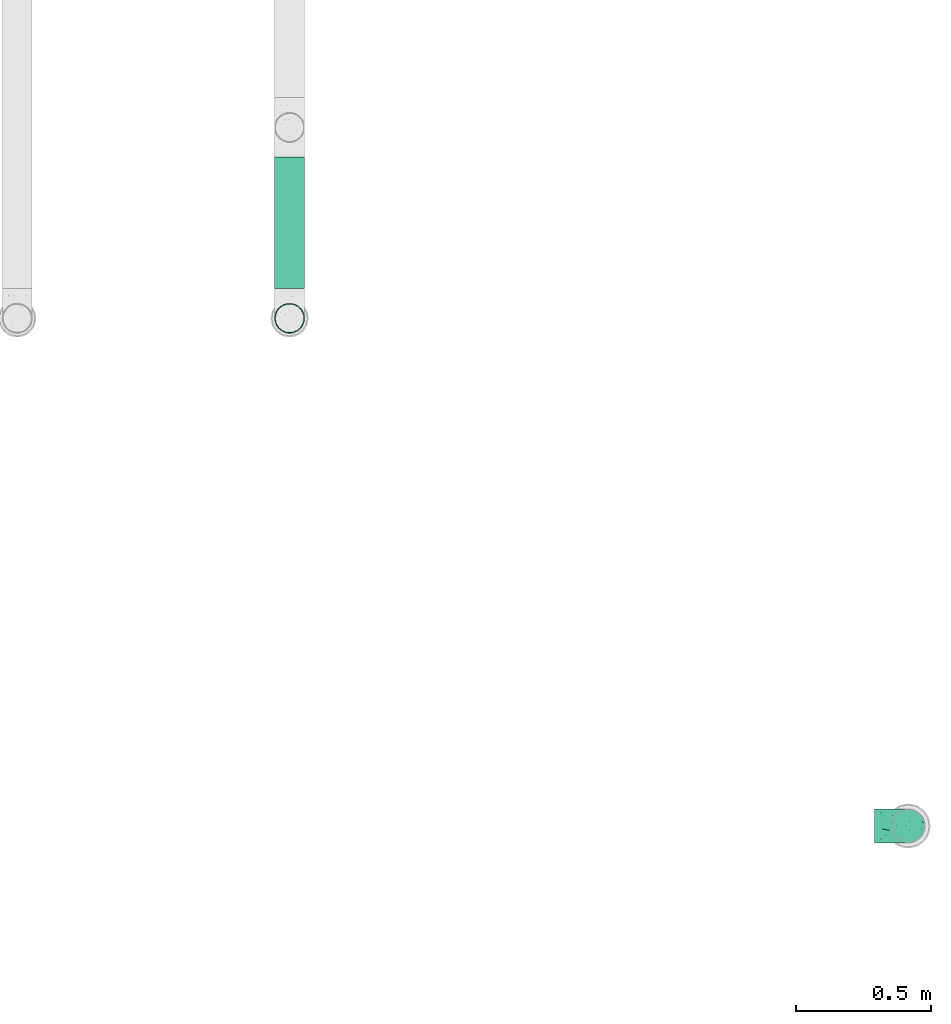
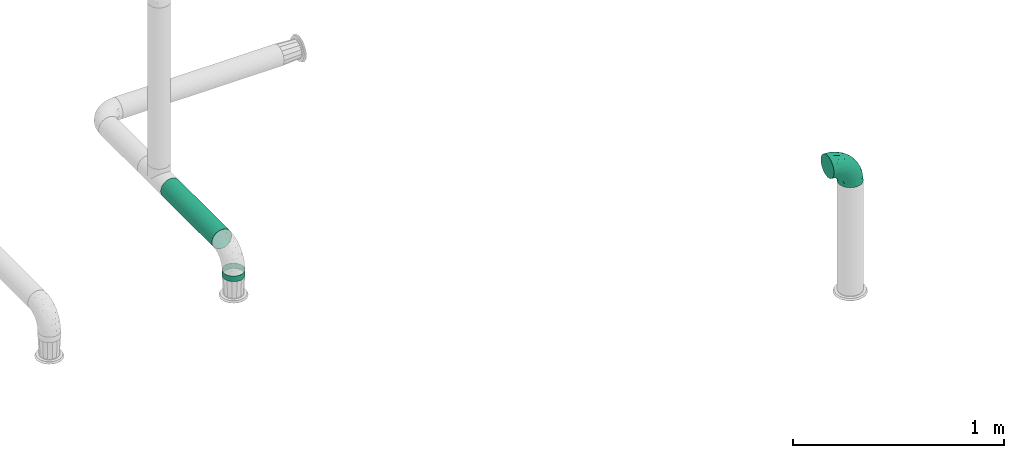
# One storey, part 95 of 103: 2 flow segments, 1 flow fitting.
"""IFC2X3 building model written with IfcOpenShell, lengths in millimetres."""

from ifc_helpers import new_model, entity, si_unit, converted_unit, derived_unit, direction, frame, origin_with_axes, origin_2d_with_axis, place, context, subcontext, project, spatial, hollow_circle, extrude, open_shell, surface_model, source, transform, mapped, material, layer, layer_set, layer_usage, type_object, element, save


model = new_model("IFC2X3")

# Units and contexts
model_context = context("Model", 3, precision=1e-05, world=origin_with_axes(), true_north=direction((0.0, 1.0)))
body_context = subcontext(model_context, "Body", "Model", "MODEL_VIEW")
ifc_project = project(units=[si_unit("AREAUNIT", "SQUARE_METRE"), si_unit("VOLUMEUNIT", "CUBIC_METRE", prefix="DECI"), si_unit("TIMEUNIT", "SECOND"), si_unit("THERMODYNAMICTEMPERATUREUNIT", "DEGREE_CELSIUS"), si_unit("PRESSUREUNIT", "PASCAL"), si_unit("MASSUNIT", "GRAM", prefix="KILO"), si_unit("LENGTHUNIT", "METRE", prefix="MILLI"), si_unit("POWERUNIT", "WATT"), si_unit("ELECTRICCURRENTUNIT", "AMPERE"), si_unit("ELECTRICVOLTAGEUNIT", "VOLT"), derived_unit("VOLUMETRICFLOWRATEUNIT", [(si_unit("VOLUMEUNIT", "CUBIC_METRE", prefix="DECI"), 1), (si_unit("TIMEUNIT", "SECOND"), -1)]), derived_unit("LINEARVELOCITYUNIT", [(si_unit("LENGTHUNIT", "METRE"), 1), (si_unit("TIMEUNIT", "SECOND"), -1)]), derived_unit("MASSDENSITYUNIT", [(si_unit("MASSUNIT", "GRAM", prefix="KILO"), 1), (si_unit("VOLUMEUNIT", "CUBIC_METRE"), -1)]), converted_unit("PLANEANGLEUNIT", "DEGREE", entity("IfcRatioMeasure", 0.01745), si_unit("PLANEANGLEUNIT", "RADIAN"), dimensions=[0, 0, 0, 0, 0, 0, 0])], contexts=[model_context])

# Site, building, storey
site_placement = place(None, origin_with_axes())
site = spatial("IfcSite", under=ifc_project, at=site_placement, CompositionType="ELEMENT")
building_placement = place(site_placement, origin_with_axes())
building = spatial("IfcBuilding", under=site, at=building_placement, Name="mc-building", CompositionType="ELEMENT")
storey_placement = place(building_placement, frame((0.0, 0.0, 5900.0), z_axis=(0.0, 0.0, 1.0), x_axis=(1.0, 0.0, 0.0)))
storey = spatial("IfcBuildingStorey", under=building, at=storey_placement, Name="3. Korrus", CompositionType="ELEMENT", Elevation=5900.0)

# Flow fitting
duct_fitting_type = type_object("IfcDuctFittingType", Name="BU", PredefinedType="BEND")
shared_shape_1 = source(origin_with_axes(), body_context, "Body", "SurfaceModel", [
    surface_model("IfcShellBasedSurfaceModel", [(-125.0, 0.0, -62.5), (-125.0, -16.17619, -60.37037), (-125.0, 16.17619, -60.37037), (-125.0, 60.37037, 16.17619), (-125.0, 31.25, -54.12659), (-125.0, 54.12659, -31.25), (-125.0, 44.19417, -44.19417), (-125.0, -62.5, 0.0), (-125.0, -60.37037, 16.17619), (-125.0, -44.19417, -44.19417), (-125.0, -31.25, -54.12659), (-125.0, -60.37037, -16.17619), (-125.0, -54.12659, -31.25), (-125.0, 60.37037, -16.17619), (-125.0, 54.12659, 31.25), (-125.0, 44.19417, 44.19417), (-125.0, 16.17619, 60.37037), (-125.0, 31.25, 54.12659), (-125.0, -16.17619, 60.37037), (-125.0, -54.12659, 31.25), (-125.0, -44.19417, 44.19417), (-125.0, -31.25, 54.12659), (-125.0, 0.0, 62.5), (-125.0, 62.5, 0.0), (-16.17619, 125.0, -60.37037), (-62.5, 125.0, 0.0), (0.0, 125.0, -62.5), (-31.25, 125.0, -54.12659), (-44.19417, 125.0, -44.19417), (-54.12659, 125.0, -31.25), (44.19417, 125.0, -44.19417), (60.37037, 125.0, 16.17619), (31.25, 125.0, -54.12659), (16.17619, 125.0, -60.37037), (54.12659, 125.0, -31.25), (60.37037, 125.0, -16.17619), (62.5, 125.0, 0.0), (-60.37037, 125.0, -16.17619), (-60.37037, 125.0, 16.17619), (-54.12659, 125.0, 31.25), (-44.19417, 125.0, 44.19417), (-31.25, 125.0, 54.12659), (0.0, 125.0, 62.5), (-16.17619, 125.0, 60.37037), (54.12659, 125.0, 31.25), (44.19417, 125.0, 44.19417), (31.25, 125.0, 54.12659), (16.17619, 125.0, 60.37037), (-72.97423, 55.32904, 49.58459), (-87.09148, 43.38651, 51.77259), (-68.69218, 37.01083, 59.02974), (-86.37288, 6.11794, 62.5), (-102.44946, 13.57266, 61.46748), (-89.31796, 30.42505, 57.74247), (-79.75876, 21.08139, 61.40263), (-85.85709, 61.60432, 36.83247), (-105.99571, 52.01835, 38.04759), (-109.23107, 25.15527, 57.74247), (-23.87288, 51.52684, 62.5), (-20.86657, 80.09577, 61.41459), (-36.41116, 67.77294, 59.36871), (-72.59833, 84.97566, 20.44471), (-84.84527, 71.68644, 22.63776), (-72.28039, 75.08953, 34.06229), (-113.17841, 59.9112, 21.05599), (-105.80839, 64.31191, 11.93589), (-111.60883, 65.16367, 0.0), (-60.71426, 105.22832, 23.91771), (-100.62332, 62.31546, 23.91771), (-13.4791, 102.54506, 61.48083), (-6.11794, 86.37288, 62.5), (-65.16367, 111.60883, 0.0), (-64.37068, 105.82697, 11.61464), (-51.52684, 23.87288, 62.5), (-50.69134, 50.69135, 59.24335), (-105.32369, 40.3031, 49.58458), (-25.28712, 108.41778, 57.74247), (-40.88389, 102.97269, 49.58458), (-49.66967, 79.07581, 50.53579), (-30.95126, 87.95323, 57.74247), (-65.09409, 90.12761, 28.38341), (-66.67939, 95.80824, 18.23245), (-94.24179, 68.59274, 14.67936), (-56.68565, 61.95245, 53.66363), (-84.74719, 75.95181, 10.86071), (-51.54332, 107.92365, 38.04759), (-67.25753, 101.08228, 0.0), (-58.54205, 89.35136, 38.04759), (-74.03168, 90.94406, 0.0), (-64.15138, 70.52814, 45.04029), (-101.08228, 67.25753, 0.0), (-80.80582, 80.80582, 0.0), (-90.94406, 74.03168, 0.0), (-107.87602, 51.55441, -38.04759), (-105.81087, 64.31979, -11.89334), (-113.23859, 59.9943, -20.79563), (-102.50484, 41.0078, -49.58458), (-90.90834, 52.91787, -43.09941), (-86.37288, 6.11794, -62.5), (-82.6746, 22.37103, -60.91508), (-51.52684, 23.87288, -62.5), (-24.90859, 74.00088, -61.20337), (-6.11794, 86.37288, -62.5), (-23.87288, 51.52684, -62.5), (-40.24859, 105.55983, -49.58458), (-103.52624, 12.53143, -61.61172), (-52.01835, 105.9957, -38.04759), (-102.84629, 26.37525, -57.74247), (-80.60061, 37.86129, -56.26993), (-89.23788, 71.99576, -13.34087), (-28.31259, 95.51825, -57.74247), (-100.89706, 62.20969, -23.91771), (-79.09001, 65.16893, -38.04759), (-83.36843, 70.98492, -26.07025), (-72.14843, 76.80808, -32.35146), (-64.31191, 105.80839, -11.93589), (-62.31546, 100.62332, -23.91771), (-61.48499, 86.19979, -36.72576), (-65.63586, 35.3365, -60.01002), (-59.9112, 113.17841, -21.05599), (-14.35128, 101.66255, -61.35337), (-39.16846, 75.52412, -56.86737), (-49.98148, 49.98148, -59.57135), (-74.75599, 82.48123, -20.09995), (-79.93714, 49.60562, -50.24944), (-65.30683, 59.08485, -51.03937), (-69.00621, 93.51335, -14.6428), (-48.12403, 84.36987, -49.58459), (-65.05902, 72.16091, -43.27513), (-91.99255, 60.8749, -33.31849), (-74.30538, -22.05025, -54.52849), (-83.27732, -57.79898, 0.0), (-93.43528, -58.70511, -11.68929), (-65.26967, -50.32842, -16.71444), (20.96007, 31.53005, -39.63719), (36.17209, 58.4237, -38.31102), (29.66468, 29.66696, -26.32537), (-59.46467, 5.17337, -61.41841), (9.88584, 35.44281, -50.43749), (-6.21876, 6.21876, -45.37394), (1.26602, -1.26602, -32.1996), (5.97284, -5.97284, -16.71444), (-29.66696, -29.66468, -26.32537), (-5.17337, 59.46467, -61.41841), (-25.56296, 25.56296, -60.51531), (-85.76554, -12.75621, -59.78088), (48.55289, 56.98302, -11.64673), (57.71969, 88.32124, -11.85826), (57.79898, 83.27732, 0.0), (-8.09566, -21.5934, 0.0), (-43.6468, -43.93166, 0.0), (-26.3245, -32.97333, -12.3928), (-83.98915, -46.13442, -36.15679), (-66.40639, -30.82245, -46.75569), (-31.53004, -20.96006, -39.63719), (-52.51367, -36.89027, -34.10077), (12.75621, 85.76554, -59.78088), (4.48155, 49.92421, -57.42403), (37.53998, 99.49287, -48.41169), (22.05025, 74.30538, -54.52849), (-15.22434, 15.22435, -54.69384), (-49.9242, -4.48154, -57.42403), (51.83554, 76.17092, -22.12398), (46.66757, 86.70304, -36.28653), (-35.4428, -9.88583, -50.43749), (21.5934, 8.09566, 0.0), (43.93166, 43.6468, 0.0), (32.97333, 26.3245, -12.3928), (-99.49287, -37.53998, -48.41169), (30.82245, 66.40639, -46.75569), (-56.98302, -48.55289, 11.64673), (-88.32124, -57.71969, 11.85826), (50.32842, 65.26967, 16.71444), (-76.17092, -51.83554, 22.12398), (-5.17337, 59.46467, 61.41841), (12.75621, 85.76554, 59.78088), (-85.76554, -12.75621, 59.78088), (-49.9242, -4.48154, 57.42403), (-59.46467, 5.17337, 61.41841), (-26.3245, -32.97333, 12.3928), (-35.4428, -9.88583, 50.43749), (-31.53004, -20.96006, 39.63719), (-6.21876, 6.21876, 45.37394), (32.97333, 26.3245, 12.3928), (5.97284, -5.97284, 16.71444), (-99.49287, -37.53998, 48.41169), (-86.70304, -46.66757, 36.28653), (9.88584, 35.44281, 50.43749), (20.96007, 31.53005, 39.63719), (-15.22434, 15.22435, 54.69384), (4.48155, 49.92421, 57.42403), (-74.30538, -22.05025, 54.52849), (-25.56296, 25.56296, 60.51531), (37.53998, 99.49287, 48.41169), (46.13442, 83.98915, 36.15679), (29.66468, 29.66696, 26.32537), (-29.66696, -29.66468, 26.32537), (1.26602, -1.26602, 32.1996), (58.70511, 93.43528, 11.68929), (30.82245, 66.40639, 46.75569), (36.89027, 52.51367, 34.10076), (22.05025, 74.30538, 54.52849), (-58.42369, -36.17209, 38.31102), (-66.40639, -30.82245, 46.75569)], [open_shell([[[0, 1, 2]], [[2, 3, 4]], [[5, 6, 3]], [[4, 3, 6]], [[2, 7, 8]], [[9, 7, 10]], [[1, 10, 7]], [[11, 7, 12]], [[9, 12, 7]], [[7, 2, 1]], [[5, 3, 13]], [[14, 3, 2]], [[15, 14, 2]], [[2, 16, 17]], [[17, 15, 2]], [[2, 18, 16]], [[2, 8, 19]], [[2, 19, 20]], [[20, 21, 2]], [[18, 2, 21]], [[18, 22, 16]], [[23, 13, 3]], [[24, 25, 26]], [[27, 25, 24]], [[25, 28, 29]], [[28, 25, 27]], [[30, 26, 31]], [[26, 32, 33]], [[26, 30, 32]], [[30, 31, 34]], [[34, 31, 35]], [[31, 36, 35]], [[29, 37, 25]], [[38, 39, 26]], [[39, 40, 26]], [[26, 41, 42]], [[41, 26, 40]], [[41, 43, 42]], [[44, 31, 26]], [[45, 44, 26]], [[26, 46, 45]], [[47, 46, 26]], [[47, 26, 42]], [[25, 38, 26]], [[48, 49, 50]], [[22, 51, 52]], [[53, 54, 50]], [[55, 56, 49]], [[56, 14, 15]], [[16, 57, 17]], [[58, 59, 60]], [[61, 62, 63]], [[3, 64, 65]], [[53, 52, 54]], [[3, 65, 66]], [[67, 39, 38]], [[56, 68, 64]], [[65, 64, 68]], [[69, 59, 70]], [[38, 71, 72]], [[73, 58, 74]], [[75, 49, 56]], [[76, 69, 43]], [[53, 57, 52]], [[77, 78, 79]], [[41, 76, 43]], [[43, 69, 42]], [[55, 68, 56]], [[15, 17, 75]], [[76, 77, 79]], [[80, 67, 81]], [[62, 82, 68]], [[60, 78, 83]], [[62, 84, 82]], [[85, 77, 40]], [[81, 67, 72]], [[86, 72, 71]], [[87, 85, 67]], [[61, 81, 88]], [[77, 41, 40]], [[78, 77, 87]], [[15, 75, 56]], [[83, 89, 48]], [[85, 40, 39]], [[62, 68, 55]], [[89, 87, 63]], [[83, 48, 50]], [[57, 75, 17]], [[49, 75, 53]], [[67, 85, 39]], [[87, 77, 85]], [[63, 62, 55]], [[89, 55, 48]], [[80, 63, 87]], [[66, 65, 90]], [[66, 23, 3]], [[84, 91, 92]], [[92, 90, 82]], [[65, 82, 90]], [[61, 84, 62]], [[92, 82, 84]], [[68, 82, 65]], [[3, 14, 64]], [[56, 64, 14]], [[38, 25, 71]], [[81, 72, 86]], [[38, 72, 67]], [[91, 61, 88]], [[80, 81, 61]], [[63, 80, 61]], [[67, 80, 87]], [[77, 76, 41]], [[79, 59, 69]], [[79, 69, 76]], [[42, 69, 70]], [[60, 59, 79]], [[58, 70, 59]], [[78, 60, 79]], [[58, 60, 74]], [[52, 57, 16]], [[75, 57, 53]], [[22, 52, 16]], [[52, 51, 54]], [[51, 73, 54]], [[50, 73, 74]], [[73, 50, 54]], [[50, 74, 83]], [[60, 83, 74]], [[89, 83, 78]], [[87, 89, 78]], [[55, 89, 63]], [[50, 49, 53]], [[55, 49, 48]], [[81, 86, 88]], [[91, 84, 61]], [[6, 5, 93]], [[90, 94, 66]], [[13, 94, 95]], [[96, 93, 97]], [[98, 99, 100]], [[96, 4, 6]], [[101, 102, 103]], [[28, 27, 104]], [[2, 105, 0]], [[104, 106, 28]], [[99, 105, 107]], [[108, 107, 96]], [[90, 109, 94]], [[107, 2, 4]], [[13, 66, 94]], [[27, 24, 110]], [[109, 111, 94]], [[112, 113, 114]], [[37, 115, 71]], [[116, 106, 117]], [[99, 118, 100]], [[116, 115, 119]], [[37, 119, 115]], [[24, 120, 110]], [[121, 110, 101]], [[119, 106, 116]], [[101, 110, 120]], [[122, 103, 100]], [[117, 123, 116]], [[124, 125, 108]], [[115, 116, 126]], [[106, 29, 28]], [[26, 102, 120]], [[127, 104, 110]], [[97, 124, 96]], [[125, 122, 118]], [[128, 127, 125]], [[96, 6, 93]], [[115, 126, 86]], [[117, 106, 127]], [[111, 113, 129]], [[95, 93, 5]], [[97, 129, 112]], [[110, 104, 27]], [[106, 104, 127]], [[96, 107, 4]], [[99, 107, 108]], [[99, 108, 118]], [[105, 99, 98]], [[112, 114, 128]], [[121, 125, 127]], [[13, 23, 66]], [[109, 90, 92]], [[94, 111, 95]], [[91, 123, 109]], [[129, 113, 112]], [[93, 95, 111]], [[5, 13, 95]], [[71, 115, 86]], [[71, 25, 37]], [[123, 91, 88]], [[126, 116, 123]], [[123, 88, 126]], [[86, 126, 88]], [[37, 29, 119]], [[106, 119, 29]], [[129, 93, 111]], [[124, 112, 125]], [[0, 105, 98]], [[107, 105, 2]], [[125, 118, 108]], [[100, 118, 122]], [[93, 129, 97]], [[113, 111, 109]], [[109, 123, 113]], [[114, 123, 117]], [[123, 114, 113]], [[128, 114, 117]], [[127, 128, 117]], [[112, 128, 125]], [[103, 122, 101]], [[110, 121, 127]], [[101, 122, 121]], [[125, 121, 122]], [[26, 120, 24]], [[101, 120, 102]], [[96, 124, 108]], [[92, 91, 109]], [[112, 124, 97]], [[10, 1, 130]], [[131, 132, 133]], [[134, 135, 136]], [[98, 100, 137]], [[138, 134, 139]], [[140, 141, 142]], [[143, 144, 103]], [[98, 145, 0]], [[146, 147, 148]], [[149, 150, 151]], [[7, 11, 132]], [[133, 12, 152]], [[153, 154, 155]], [[152, 12, 9]], [[156, 157, 143]], [[142, 151, 133]], [[155, 133, 152]], [[158, 159, 32]], [[136, 141, 140]], [[137, 145, 98]], [[103, 144, 100]], [[133, 132, 12]], [[160, 161, 144]], [[137, 144, 161]], [[160, 144, 157]], [[156, 26, 33]], [[130, 1, 145]], [[34, 162, 163]], [[164, 139, 154]], [[30, 158, 32]], [[160, 138, 139]], [[163, 30, 34]], [[156, 159, 157]], [[149, 141, 165]], [[146, 166, 167]], [[168, 9, 10]], [[36, 148, 147]], [[9, 168, 152]], [[150, 131, 133]], [[166, 146, 148]], [[166, 165, 167]], [[141, 136, 167]], [[160, 164, 161]], [[143, 103, 102]], [[151, 141, 149]], [[35, 162, 34]], [[135, 162, 136]], [[158, 163, 169]], [[144, 137, 100]], [[145, 137, 161]], [[145, 161, 130]], [[145, 1, 0]], [[102, 26, 156]], [[144, 143, 157]], [[102, 156, 143]], [[159, 33, 32]], [[141, 167, 165]], [[146, 136, 162]], [[133, 151, 150]], [[141, 151, 142]], [[164, 130, 161]], [[130, 153, 168]], [[159, 156, 33]], [[138, 159, 169]], [[138, 160, 157]], [[164, 160, 139]], [[154, 140, 142]], [[134, 140, 139]], [[159, 138, 157]], [[134, 136, 140]], [[138, 169, 134]], [[135, 134, 169]], [[139, 140, 154]], [[130, 164, 153]], [[155, 154, 142]], [[153, 164, 154]], [[136, 146, 167]], [[146, 162, 147]], [[162, 35, 147]], [[36, 147, 35]], [[130, 168, 10]], [[152, 168, 153]], [[163, 158, 30]], [[159, 158, 169]], [[7, 132, 131]], [[12, 132, 11]], [[169, 163, 135]], [[135, 163, 162]], [[133, 155, 142]], [[153, 155, 152]], [[150, 170, 131]], [[171, 7, 131]], [[166, 148, 172]], [[8, 173, 19]], [[174, 175, 70]], [[176, 177, 178]], [[149, 179, 150]], [[170, 150, 179]], [[180, 181, 182]], [[165, 183, 184]], [[20, 185, 21]], [[20, 19, 186]], [[187, 182, 188]], [[189, 187, 190]], [[185, 191, 21]], [[22, 18, 176]], [[190, 192, 189]], [[189, 180, 182]], [[178, 73, 51]], [[19, 173, 186]], [[149, 165, 184]], [[45, 193, 194]], [[191, 177, 176]], [[165, 166, 183]], [[195, 183, 172]], [[196, 184, 197]], [[194, 44, 45]], [[198, 36, 31]], [[199, 188, 200]], [[172, 198, 44]], [[193, 45, 46]], [[194, 200, 172]], [[175, 42, 70]], [[192, 58, 73]], [[170, 171, 131]], [[189, 192, 177]], [[70, 58, 174]], [[190, 174, 192]], [[179, 184, 196]], [[197, 184, 195]], [[47, 201, 46]], [[181, 202, 196]], [[148, 198, 172]], [[201, 47, 175]], [[172, 44, 194]], [[178, 192, 73]], [[202, 173, 196]], [[185, 186, 203]], [[192, 174, 58]], [[175, 174, 190]], [[175, 190, 201]], [[175, 47, 42]], [[51, 22, 176]], [[192, 178, 177]], [[51, 176, 178]], [[191, 18, 21]], [[184, 179, 149]], [[170, 196, 173]], [[172, 183, 166]], [[184, 183, 195]], [[187, 201, 190]], [[201, 199, 193]], [[191, 176, 18]], [[180, 191, 203]], [[180, 189, 177]], [[187, 189, 182]], [[188, 197, 195]], [[181, 197, 182]], [[191, 180, 177]], [[181, 196, 197]], [[180, 203, 181]], [[202, 181, 203]], [[182, 197, 188]], [[201, 187, 199]], [[200, 188, 195]], [[199, 187, 188]], [[196, 170, 179]], [[170, 173, 171]], [[173, 8, 171]], [[7, 171, 8]], [[201, 193, 46]], [[194, 193, 199]], [[186, 185, 20]], [[191, 185, 203]], [[36, 198, 148]], [[44, 198, 31]], [[203, 186, 202]], [[202, 186, 173]], [[172, 200, 195]], [[199, 200, 194]]])]),
])
flow_fitting_placement = place(storey_placement, frame((36404.9937, 6304.03427, 3215.0), z_axis=(0.0, -1.0, 0.0), x_axis=(0.0, 0.0, 1.0)))
element("IfcFlowFitting", 1, at=flow_fitting_placement, inside=storey, type_object=duct_fitting_type, Name="BU", context=body_context, shape_type="MappedRepresentation", body=[
    mapped(shared_shape_1, transform((0.0, 0.0, 0.0), scale=1.0)),
])

# Flow segments
ifc_material = material(Name="FZ1")
ifc_layer = layer(ifc_material, 0.0)
ifc_layer_set = layer_set([ifc_layer], Name="FZ1")
ifc_layer_usage = layer_usage(ifc_layer_set, "AXIS1", "POSITIVE", 0.0)
duct_segment_type = type_object("IfcDuctSegmentType", PredefinedType="RIGIDSEGMENT")
shared_shape_2 = source(origin_with_axes(), body_context, "Body", "SweptSolid", [
    extrude(hollow_circle(Radius=55.0, WallThickness=2.0, at=origin_2d_with_axis()), frame((0.0, 0.0, 0.0), z_axis=(1.0, 0.0, 0.0), x_axis=(0.0, 1.0, 0.0)), (0.0, 0.0, 1.0), 31.9),
])
flow_segment_1_placement = place(storey_placement, frame((34114.97365, 8183.57591, 2235.0), z_axis=(0.0, 1.0, 0.0), x_axis=(0.0, 0.0, -1.0)))
element("IfcFlowSegment", 2, at=flow_segment_1_placement, inside=storey, type_object=duct_segment_type, material=ifc_layer_usage, context=body_context, shape_type="MappedRepresentation", body=[
    mapped(shared_shape_2, transform((0.0, 0.0, 0.0), scale=1.0)),
])
shared_shape_3 = source(origin_with_axes(), body_context, "Body", "SweptSolid", [
    extrude(hollow_circle(Radius=55.0, WallThickness=2.0, at=origin_2d_with_axis()), frame((0.0, 0.0, 0.0), z_axis=(1.0, 0.0, 0.0), x_axis=(0.0, 1.0, 0.0)), (0.0, 0.0, 1.0), 486.5),
])
flow_segment_2_placement = place(storey_placement, frame((34114.97365, 8780.09332, 2345.0), z_axis=(0.0, 0.0, 1.0), x_axis=(0.0, -1.0, 0.0)))
element("IfcFlowSegment", 3, at=flow_segment_2_placement, inside=storey, type_object=duct_segment_type, material=ifc_layer_usage, context=body_context, shape_type="MappedRepresentation", body=[
    mapped(shared_shape_3, transform((0.0, 0.0, 0.0), scale=1.0)),
])

save(model, "model.ifc")
